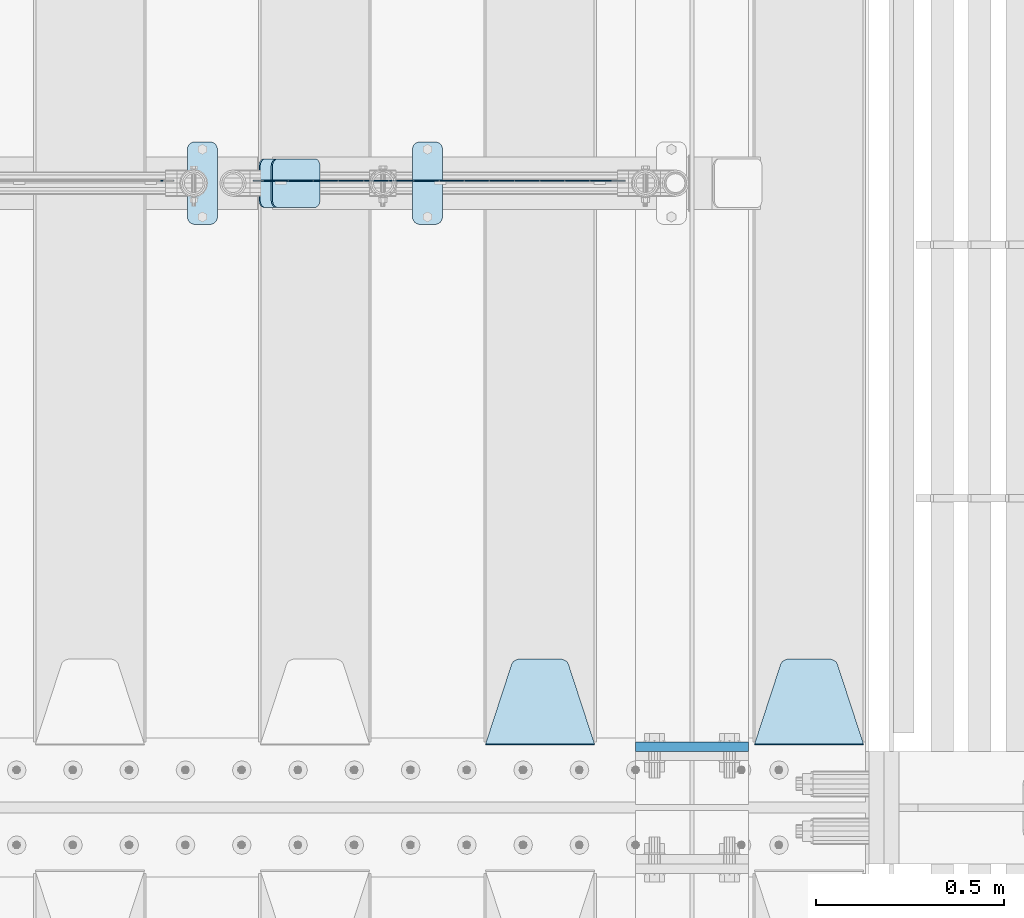
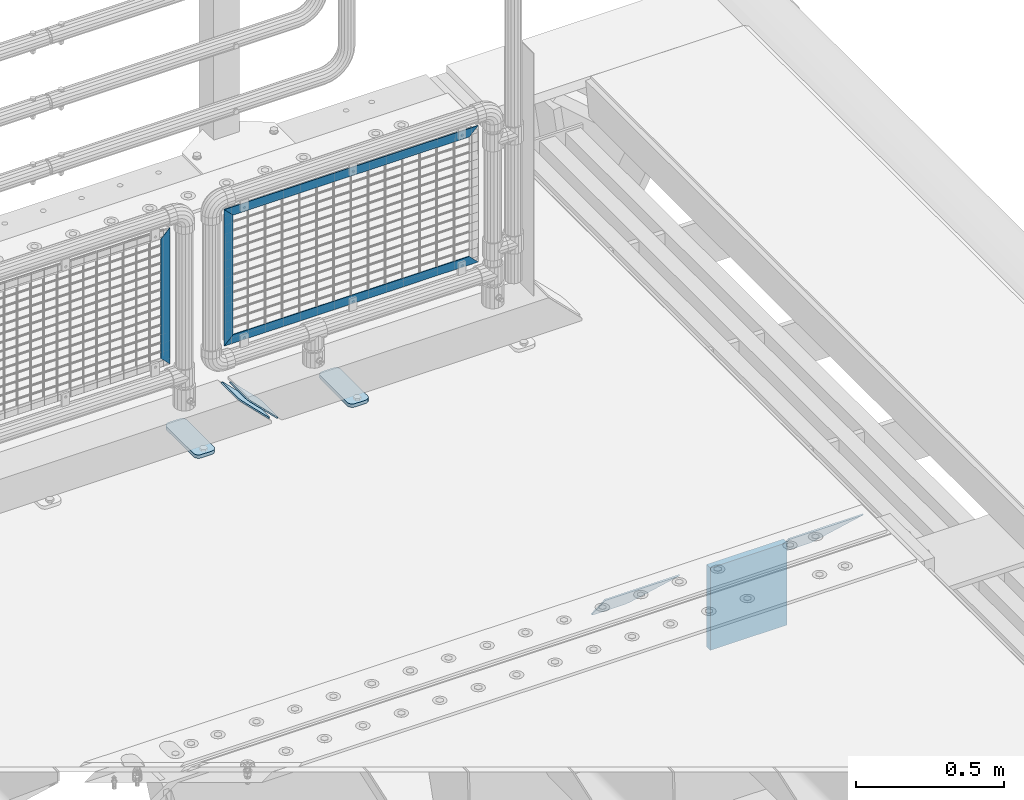
# One storey, part 177 of 193: 11 plates.
"""IFC2X3 building model written with IfcOpenShell, lengths in millimetres."""

from ifc_helpers import new_model, si_unit, frame, origin_with_axes, place, context, subcontext, project, spatial, faceted_brep, material, type_object, element, save


model = new_model("IFC2X3")

# Units and contexts
model_context = context("Model", 3, precision=1e-05, world=origin_with_axes())
body_context = subcontext(model_context, "Body", "Model", "MODEL_VIEW")
ifc_project = project(units=[si_unit("LENGTHUNIT", "METRE", prefix="MILLI"), si_unit("AREAUNIT", "SQUARE_METRE"), si_unit("VOLUMEUNIT", "CUBIC_METRE"), si_unit("MASSUNIT", "GRAM", prefix="KILO"), si_unit("TIMEUNIT", "SECOND"), si_unit("PLANEANGLEUNIT", "RADIAN"), si_unit("SOLIDANGLEUNIT", "STERADIAN"), si_unit("THERMODYNAMICTEMPERATUREUNIT", "DEGREE_CELSIUS"), si_unit("LUMINOUSINTENSITYUNIT", "LUMEN")], contexts=[model_context])

# Site, building, storey
site_placement = place(None, origin_with_axes())
site = spatial("IfcSite", under=ifc_project, at=site_placement, CompositionType="ELEMENT")
building_placement = place(site_placement, origin_with_axes())
building = spatial("IfcBuilding", under=site, at=building_placement, Name="Standard", CompositionType="ELEMENT")
storey_placement = place(building_placement, origin_with_axes())
storey = spatial("IfcBuildingStorey", under=building, at=storey_placement, Name="Undefined", CompositionType="ELEMENT", Elevation=0.0)

# Plates
ifc_material_1 = material(Name="STEEL/S355N")
plate_type_1 = type_object("IfcPlateType", PredefinedType="NOTDEFINED")
plate_1_placement = place(storey_placement, frame((-29045.0, 27162.5, -340.000000000044), z_axis=(0.0, 0.0, 1.0), x_axis=(1.0, 0.0, 0.0)))
element("IfcPlate", 1, at=plate_1_placement, inside=storey, type_object=plate_type_1, material=ifc_material_1, context=body_context, shape_type="Brep", body=[
    faceted_brep([(0.0, -12.5, 0.0), (9.27684595808387e-10, -12.5, 340.0), (9.27684595808387e-10, 12.5, 340.0), (0.0, 12.5, 0.0), (300.0, -12.5, 340.0), (300.0, 12.5, 340.0), (300.0, -12.5, 0.0), (300.0, 12.5, 0.0)], [[[0, 1, 2, 3]], [[1, 4, 5, 2]], [[4, 6, 7, 5]], [[6, 0, 3, 7]], [[5, 7, 3, 2]], [[6, 4, 1, 0]]]),
])
plate_type_2 = type_object("IfcPlateType", PredefinedType="NOTDEFINED")
plate_2_placement = place(storey_placement, frame((-28438.0, 27168.232233047, -1.76776695296758), z_axis=(0.0, 0.707106781186547, -0.707106781186548), x_axis=(-1.0, 0.0, 0.0)))
element("IfcPlate", 2, at=plate_2_placement, inside=storey, type_object=plate_type_2, material=ifc_material_1, context=body_context, shape_type="Brep", body=[
    faceted_brep([(0.0, -2.5, 0.0), (69.345504679477, -2.50000000000364, 300.171731424831), (69.345504679477, 2.49999999999636, 300.171731424831), (0.0, 2.5, 0.0), (70.9274061199576, -2.50000000000364, 304.897442415397), (70.9274061199576, 2.49999999999636, 304.897442415397), (73.3818627772307, -2.50000000000364, 309.234538108529), (73.3818627772307, 2.49999999999636, 309.234538108529), (76.6187032999551, -2.50000000000728, 313.023683126103), (76.6187032999551, 2.49999999999636, 313.023683126103), (80.5190132704993, -2.50000000000364, 316.125672595372), (80.5190132704993, 2.49999999999636, 316.125672595368), (84.9395038596849, -2.50000000000364, 318.426546230472), (84.9395038596849, 2.49999999999636, 318.426546230476), (89.7177759439219, -2.50000000000364, 319.841774983273), (89.7177759439219, 2.49999999999636, 319.841774983277), (94.678286292652, -2.50000000000364, 320.319366455074), (94.678286292652, 2.49999999999636, 320.319366455074), (195.321713707348, -2.50000000000364, 320.319366455074), (195.321713707348, 2.49999999999636, 320.319366455074), (200.282224056078, -2.50000000000364, 319.841774983273), (200.282224056078, 2.49999999999636, 319.841774983277), (205.060496140315, -2.50000000000364, 318.426546230472), (205.060496140315, 2.49999999999636, 318.426546230472), (209.480986729501, -2.50000000000364, 316.125672595372), (209.480986729501, 2.49999999999636, 316.125672595368), (213.381296700045, -2.50000000000728, 313.023683126103), (213.381296700045, 2.49999999999272, 313.023683126103), (216.618137222769, -2.50000000000364, 309.234538108525), (216.618137222769, 2.49999999999636, 309.234538108522), (219.072593880042, -2.50000000000364, 304.897442415397), (219.072593880042, 2.49999999999636, 304.897442415397), (220.654495320523, -2.50000000000364, 300.171731424831), (220.654495320523, 2.49999999999636, 300.171731424831), (290.0, -2.50000000000364, 0.0), (290.0, 2.49999999999636, 0.0)], [[[0, 1, 2, 3]], [[1, 4, 5, 2]], [[4, 6, 7, 5]], [[6, 8, 9, 7]], [[8, 10, 11, 9]], [[10, 12, 13, 11]], [[12, 14, 15, 13]], [[14, 16, 17, 15]], [[16, 18, 19, 17]], [[18, 20, 21, 19]], [[20, 22, 23, 21]], [[22, 24, 25, 23]], [[24, 26, 27, 25]], [[26, 28, 29, 27]], [[28, 30, 31, 29]], [[30, 32, 33, 31]], [[32, 34, 35, 33]], [[34, 0, 3, 35]], [[5, 7, 9, 11, 13, 15, 17, 19, 21, 23, 25, 27, 29, 31, 33, 35, 3, 2]], [[34, 32, 30, 28, 26, 24, 22, 20, 18, 16, 14, 12, 10, 8, 6, 4, 1, 0]]]),
])
plate_3_placement = place(storey_placement, frame((-29155.0, 27168.232233047, -1.76776695296758), z_axis=(0.0, 0.707106781186547, -0.707106781186548), x_axis=(-1.0, 0.0, 0.0)))
element("IfcPlate", 3, at=plate_3_placement, inside=storey, type_object=plate_type_2, material=ifc_material_1, context=body_context, shape_type="Brep", body=[
    faceted_brep([(0.0, -2.5, 0.0), (69.345504679477, -2.50000000000364, 300.171731424831), (69.345504679477, 2.49999999999636, 300.171731424831), (0.0, 2.5, 0.0), (70.9274061199576, -2.50000000000364, 304.897442415397), (70.9274061199576, 2.49999999999636, 304.897442415397), (73.3818627772307, -2.50000000000364, 309.234538108529), (73.3818627772307, 2.49999999999636, 309.234538108529), (76.6187032999551, -2.50000000000728, 313.023683126103), (76.6187032999551, 2.49999999999636, 313.023683126103), (80.5190132704993, -2.50000000000364, 316.125672595372), (80.5190132704993, 2.49999999999636, 316.125672595368), (84.9395038596849, -2.50000000000364, 318.426546230472), (84.9395038596849, 2.49999999999636, 318.426546230476), (89.7177759439219, -2.50000000000364, 319.841774983273), (89.7177759439219, 2.49999999999636, 319.841774983277), (94.678286292652, -2.50000000000364, 320.319366455074), (94.678286292652, 2.49999999999636, 320.319366455074), (195.321713707348, -2.50000000000364, 320.319366455074), (195.321713707348, 2.49999999999636, 320.319366455074), (200.282224056078, -2.50000000000364, 319.841774983273), (200.282224056078, 2.49999999999636, 319.841774983277), (205.060496140315, -2.50000000000364, 318.426546230472), (205.060496140315, 2.49999999999636, 318.426546230472), (209.480986729501, -2.50000000000364, 316.125672595372), (209.480986729501, 2.49999999999636, 316.125672595368), (213.381296700045, -2.50000000000728, 313.023683126103), (213.381296700045, 2.49999999999272, 313.023683126103), (216.618137222769, -2.50000000000364, 309.234538108525), (216.618137222769, 2.49999999999636, 309.234538108522), (219.072593880042, -2.50000000000364, 304.897442415397), (219.072593880042, 2.49999999999636, 304.897442415397), (220.654495320523, -2.50000000000364, 300.171731424831), (220.654495320523, 2.49999999999636, 300.171731424831), (290.0, -2.50000000000364, 0.0), (290.0, 2.49999999999636, 0.0)], [[[0, 1, 2, 3]], [[1, 4, 5, 2]], [[4, 6, 7, 5]], [[6, 8, 9, 7]], [[8, 10, 11, 9]], [[10, 12, 13, 11]], [[12, 14, 15, 13]], [[14, 16, 17, 15]], [[16, 18, 19, 17]], [[18, 20, 21, 19]], [[20, 22, 23, 21]], [[22, 24, 25, 23]], [[24, 26, 27, 25]], [[26, 28, 29, 27]], [[28, 30, 31, 29]], [[30, 32, 33, 31]], [[32, 34, 35, 33]], [[34, 0, 3, 35]], [[5, 7, 9, 11, 13, 15, 17, 19, 21, 23, 25, 27, 29, 31, 33, 35, 3, 2]], [[34, 32, 30, 28, 26, 24, 22, 20, 18, 16, 14, 12, 10, 8, 6, 4, 1, 0]]]),
])
ifc_material_2 = material(Name="Misc_Undefined")
plate_type_3 = type_object("IfcPlateType", PredefinedType="NOTDEFINED")
plate_4_placement = place(storey_placement, frame((-30029.8899741176, 28670.4999645044, 879.520017263591), z_axis=(-0.707106781186548, 0.0, -0.707106781186548), x_axis=(-0.707106781186548, 0.0, 0.707106781186548)))
element("IfcPlate", 4, at=plate_4_placement, inside=storey, type_object=plate_type_3, material=ifc_material_2, context=body_context, shape_type="Brep", body=[
    faceted_brep([(0.0, -1.49999999999636, 3.63797880709171e-12), (-348.603637695382, -1.49999999999636, 348.603668212894), (-348.603637695382, 1.50000000000364, 348.603668212891), (0.0, 1.50000000000364, 7.27595761418343e-12), (-348.603637695389, -1.49999999999636, 398.101165771488), (-348.603637695385, 1.50000000000364, 398.101165771488), (49.4974975585938, -1.5, 2.5465851649642e-11), (49.4974975585938, 1.50000000000364, 2.5465851649642e-11)], [[[0, 1, 2, 3]], [[1, 4, 5, 2]], [[4, 6, 7, 5]], [[6, 0, 3, 7]], [[5, 7, 3, 2]], [[6, 4, 1, 0]]]),
])
plate_5_placement = place(storey_placement, frame((-30029.8899996664, 28670.4999883292, 386.520006105211), z_axis=(0.707106781186548, 0.0, -0.707106781186548), x_axis=(-0.707106781186548, 0.0, -0.707106781186548)))
element("IfcPlate", 5, at=plate_5_placement, inside=storey, type_object=plate_type_3, material=ifc_material_2, context=body_context, shape_type="Brep", body=[
    faceted_brep([(0.0, -1.49999999999636, 3.63797880709171e-12), (-651.521057128932, -1.49999999999636, 651.521179199211), (-651.521057128935, 1.50000000000364, 651.521179199211), (0.0, 1.50000000000364, 7.27595761418343e-12), (-651.521057128939, -1.49999999999636, 701.018676757805), (-651.521057128935, 1.50000000000364, 701.018676757809), (49.4974975585938, -1.5, 2.5465851649642e-11), (49.4974975585938, 1.50000000000364, 2.5465851649642e-11)], [[[0, 1, 2, 3]], [[1, 4, 5, 2]], [[4, 6, 7, 5]], [[6, 0, 3, 7]], [[5, 7, 3, 2]], [[6, 4, 1, 0]]]),
])
plate_6_placement = place(storey_placement, frame((-29073.5000006033, 28670.4997837706, 914.520000514844), z_axis=(-0.707106781186548, 0.0, 0.707106781186548), x_axis=(-0.707106781186548, 0.0, -0.707106781186548)))
element("IfcPlate", 6, at=plate_6_placement, inside=storey, type_object=plate_type_3, material=ifc_material_2, context=body_context, shape_type="Brep", body=[
    faceted_brep([(0.0, -1.49999999999636, 3.63797880709171e-12), (701.01855468754, -1.50000000000728, 701.018615722656), (701.01855468754, 1.49999999999272, 701.018615722656), (0.0, 1.50000000000364, 7.27595761418343e-12), (701.018554687536, -1.50000000000728, 651.521118164059), (701.018554687536, 1.49999999999272, 651.521118164063), (49.4974975585938, -1.5, 2.5465851649642e-11), (49.4974975585938, 1.50000000000364, 2.5465851649642e-11)], [[[0, 1, 2, 3]], [[1, 4, 5, 2]], [[4, 6, 7, 5]], [[6, 0, 3, 7]], [[5, 7, 3, 2]], [[6, 4, 1, 0]]]),
])
plate_7_placement = place(storey_placement, frame((-30311.5003125164, 28670.5, 879.52), z_axis=(0.707103624179499, 0.0, -0.707109938179501), x_axis=(0.707109938179495, 0.0, 0.707103624179505)))
element("IfcPlate", 7, at=plate_7_placement, inside=storey, type_object=plate_type_3, material=ifc_material_2, context=body_context, shape_type="Brep", body=[
    faceted_brep([(0.0, -1.49999999999636, 3.63797880709171e-12), (-348.605163574215, -1.5, 348.602081298824), (-348.605163574215, 1.5, 348.602081298824), (0.0, 1.50000000000364, 7.27595761418343e-12), (-348.605163574215, -1.5, 398.099334716793), (-348.605163574215, 1.5, 398.099334716793), (49.4976959228552, -1.5, -1.01863406598568e-10), (49.4976959228552, 1.5, -1.01863406598568e-10)], [[[0, 1, 2, 3]], [[1, 4, 5, 2]], [[4, 6, 7, 5]], [[6, 0, 3, 7]], [[5, 7, 3, 2]], [[6, 4, 1, 0]]]),
])
ifc_material_3 = material(Name="STEEL/S355J2")
plate_type_4 = type_object("IfcPlateType", PredefinedType="NOTDEFINED")
plate_8_placement = place(storey_placement, frame((-30240.0, 28774.5, 21.0199999999977), z_axis=(1.0, 0.0, 0.0), x_axis=(0.0, -1.0, 0.0)))
element("IfcPlate", 8, at=plate_8_placement, inside=storey, type_object=plate_type_4, material=ifc_material_3, context=body_context, shape_type="Brep", body=[
    faceted_brep([(0.0, -7.0, 20.0), (0.0, -7.0, 60.0), (0.0, 7.0, 60.0), (0.0, 7.0, 20.0), (0.384294391937146, -7.0, 63.9018064403208), (0.384294391937146, 7.0, 63.9018064403208), (1.52240934977453, -7.0, 67.6536686473009), (1.52240934977453, 7.0, 67.6536686473009), (3.37060775395003, -7.0, 71.1114046603907), (3.37060775395003, 7.0, 71.1114046603907), (5.8578643762703, -7.0, 74.1421356237297), (5.8578643762703, 7.0, 74.1421356237297), (8.88859533960931, -7.0, 76.62939224605), (8.88859533960931, 7.0, 76.62939224605), (12.3463313526991, -7.0, 78.4775906502255), (12.3463313526991, 7.0, 78.4775906502255), (16.0981935596792, -7.0, 79.6157056080629), (16.0981935596792, 7.0, 79.6157056080629), (20.0, -7.0, 80.0), (20.0, 7.0, 80.0), (200.0, -7.0, 80.0), (200.0, 7.0, 80.0), (203.901806440321, -7.0, 79.6157056080629), (203.901806440321, 7.0, 79.6157056080629), (207.653668647301, -7.0, 78.4775906502255), (207.653668647301, 7.0, 78.4775906502255), (211.111404660391, -7.0, 76.62939224605), (211.111404660391, 7.0, 76.62939224605), (214.14213562373, -7.0, 74.1421356237297), (214.14213562373, 7.0, 74.1421356237297), (216.62939224605, -7.0, 71.1114046603907), (216.62939224605, 7.0, 71.1114046603907), (218.477590650225, -7.0, 67.6536686473009), (218.477590650225, 7.0, 67.6536686473009), (219.615705608063, -7.0, 63.9018064403208), (219.615705608063, 7.0, 63.9018064403208), (220.0, -7.0, 60.0), (220.0, 7.0, 60.0), (220.0, -7.0, 20.0), (220.0, 7.0, 20.0), (219.615705608063, -7.0, 16.0981935596792), (219.615705608063, 7.0, 16.0981935596792), (218.477590650225, -7.0, 12.3463313526991), (218.477590650225, 7.0, 12.3463313526991), (216.62939224605, -7.0, 8.88859533960931), (216.62939224605, 7.0, 8.88859533960931), (214.14213562373, -7.0, 5.8578643762703), (214.14213562373, 7.0, 5.8578643762703), (211.111404660391, -7.0, 3.37060775395003), (211.111404660391, 7.0, 3.37060775395003), (207.653668647301, -7.0, 1.52240934977453), (207.653668647301, 7.0, 1.52240934977453), (203.901806440321, -7.0, 0.384294391937146), (203.901806440321, 7.0, 0.384294391937146), (200.0, -7.0, 0.0), (200.0, 7.0, 0.0), (20.0, -7.0, 0.0), (20.0, 7.0, 0.0), (16.0981935596792, -7.0, 0.384294391937146), (16.0981935596792, 7.0, 0.384294391937146), (12.3463313526991, -7.0, 1.52240934977453), (12.3463313526991, 7.0, 1.52240934977453), (8.88859533960931, -7.0, 3.37060775395003), (8.88859533960931, 7.0, 3.37060775395003), (5.8578643762703, -7.0, 5.8578643762703), (5.8578643762703, 7.0, 5.8578643762703), (3.37060775395003, -7.0, 8.88859533960931), (3.37060775395003, 7.0, 8.88859533960931), (1.52240934977453, -7.0, 12.3463313526991), (1.52240934977453, 7.0, 12.3463313526991), (0.384294391937146, -7.0, 16.0981935596792), (0.384294391937146, 7.0, 16.0981935596792)], [[[0, 1, 2, 3]], [[1, 4, 5, 2]], [[4, 6, 7, 5]], [[6, 8, 9, 7]], [[8, 10, 11, 9]], [[10, 12, 13, 11]], [[12, 14, 15, 13]], [[14, 16, 17, 15]], [[16, 18, 19, 17]], [[18, 20, 21, 19]], [[20, 22, 23, 21]], [[22, 24, 25, 23]], [[24, 26, 27, 25]], [[26, 28, 29, 27]], [[28, 30, 31, 29]], [[30, 32, 33, 31]], [[32, 34, 35, 33]], [[34, 36, 37, 35]], [[36, 38, 39, 37]], [[38, 40, 41, 39]], [[40, 42, 43, 41]], [[42, 44, 45, 43]], [[44, 46, 47, 45]], [[46, 48, 49, 47]], [[48, 50, 51, 49]], [[50, 52, 53, 51]], [[52, 54, 55, 53]], [[54, 56, 57, 55]], [[56, 58, 59, 57]], [[58, 60, 61, 59]], [[60, 62, 63, 61]], [[62, 64, 65, 63]], [[64, 66, 67, 65]], [[66, 68, 69, 67]], [[68, 70, 71, 69]], [[70, 0, 3, 71]], [[5, 7, 9, 11, 13, 15, 17, 19, 21, 23, 25, 27, 29, 31, 33, 35, 37, 39, 41, 43, 45, 47, 49, 51, 53, 55, 57, 59, 61, 63, 65, 67, 69, 71, 3, 2]], [[70, 68, 66, 64, 62, 60, 58, 56, 54, 52, 50, 48, 46, 44, 42, 40, 38, 36, 34, 32, 30, 28, 26, 24, 22, 20, 18, 16, 14, 12, 10, 8, 6, 4, 1, 0]]]),
])
plate_9_placement = place(storey_placement, frame((-29640.0, 28774.5, 21.0199999999977), z_axis=(1.0, 0.0, 0.0), x_axis=(0.0, -1.0, 0.0)))
element("IfcPlate", 9, at=plate_9_placement, inside=storey, type_object=plate_type_4, material=ifc_material_3, context=body_context, shape_type="Brep", body=[
    faceted_brep([(0.0, -7.0, 20.0), (0.0, -7.0, 60.0), (0.0, 7.0, 60.0), (0.0, 7.0, 20.0), (0.384294391937146, -7.0, 63.9018064403208), (0.384294391937146, 7.0, 63.9018064403208), (1.52240934977453, -7.0, 67.6536686473009), (1.52240934977453, 7.0, 67.6536686473009), (3.37060775395003, -7.0, 71.1114046603907), (3.37060775395003, 7.0, 71.1114046603907), (5.8578643762703, -7.0, 74.1421356237297), (5.8578643762703, 7.0, 74.1421356237297), (8.88859533960931, -7.0, 76.62939224605), (8.88859533960931, 7.0, 76.62939224605), (12.3463313526991, -7.0, 78.4775906502255), (12.3463313526991, 7.0, 78.4775906502255), (16.0981935596792, -7.0, 79.6157056080629), (16.0981935596792, 7.0, 79.6157056080629), (20.0, -7.0, 80.0), (20.0, 7.0, 80.0), (200.0, -7.0, 80.0), (200.0, 7.0, 80.0), (203.901806440321, -7.0, 79.6157056080629), (203.901806440321, 7.0, 79.6157056080629), (207.653668647301, -7.0, 78.4775906502255), (207.653668647301, 7.0, 78.4775906502255), (211.111404660391, -7.0, 76.62939224605), (211.111404660391, 7.0, 76.62939224605), (214.14213562373, -7.0, 74.1421356237297), (214.14213562373, 7.0, 74.1421356237297), (216.62939224605, -7.0, 71.1114046603907), (216.62939224605, 7.0, 71.1114046603907), (218.477590650225, -7.0, 67.6536686473009), (218.477590650225, 7.0, 67.6536686473009), (219.615705608063, -7.0, 63.9018064403208), (219.615705608063, 7.0, 63.9018064403208), (220.0, -7.0, 60.0), (220.0, 7.0, 60.0), (220.0, -7.0, 20.0), (220.0, 7.0, 20.0), (219.615705608063, -7.0, 16.0981935596792), (219.615705608063, 7.0, 16.0981935596792), (218.477590650225, -7.0, 12.3463313526991), (218.477590650225, 7.0, 12.3463313526991), (216.62939224605, -7.0, 8.88859533960931), (216.62939224605, 7.0, 8.88859533960931), (214.14213562373, -7.0, 5.8578643762703), (214.14213562373, 7.0, 5.8578643762703), (211.111404660391, -7.0, 3.37060775395003), (211.111404660391, 7.0, 3.37060775395003), (207.653668647301, -7.0, 1.52240934977453), (207.653668647301, 7.0, 1.52240934977453), (203.901806440321, -7.0, 0.384294391937146), (203.901806440321, 7.0, 0.384294391937146), (200.0, -7.0, 0.0), (200.0, 7.0, 0.0), (20.0, -7.0, 0.0), (20.0, 7.0, 0.0), (16.0981935596792, -7.0, 0.384294391937146), (16.0981935596792, 7.0, 0.384294391937146), (12.3463313526991, -7.0, 1.52240934977453), (12.3463313526991, 7.0, 1.52240934977453), (8.88859533960931, -7.0, 3.37060775395003), (8.88859533960931, 7.0, 3.37060775395003), (5.8578643762703, -7.0, 5.8578643762703), (5.8578643762703, 7.0, 5.8578643762703), (3.37060775395003, -7.0, 8.88859533960931), (3.37060775395003, 7.0, 8.88859533960931), (1.52240934977453, -7.0, 12.3463313526991), (1.52240934977453, 7.0, 12.3463313526991), (0.384294391937146, -7.0, 16.0981935596792), (0.384294391937146, 7.0, 16.0981935596792)], [[[0, 1, 2, 3]], [[1, 4, 5, 2]], [[4, 6, 7, 5]], [[6, 8, 9, 7]], [[8, 10, 11, 9]], [[10, 12, 13, 11]], [[12, 14, 15, 13]], [[14, 16, 17, 15]], [[16, 18, 19, 17]], [[18, 20, 21, 19]], [[20, 22, 23, 21]], [[22, 24, 25, 23]], [[24, 26, 27, 25]], [[26, 28, 29, 27]], [[28, 30, 31, 29]], [[30, 32, 33, 31]], [[32, 34, 35, 33]], [[34, 36, 37, 35]], [[36, 38, 39, 37]], [[38, 40, 41, 39]], [[40, 42, 43, 41]], [[42, 44, 45, 43]], [[44, 46, 47, 45]], [[46, 48, 49, 47]], [[48, 50, 51, 49]], [[50, 52, 53, 51]], [[52, 54, 55, 53]], [[54, 56, 57, 55]], [[56, 58, 59, 57]], [[58, 60, 61, 59]], [[60, 62, 63, 61]], [[62, 64, 65, 63]], [[64, 66, 67, 65]], [[66, 68, 69, 67]], [[68, 70, 71, 69]], [[70, 0, 3, 71]], [[5, 7, 9, 11, 13, 15, 17, 19, 21, 23, 25, 27, 29, 31, 33, 35, 37, 39, 41, 43, 45, 47, 49, 51, 53, 55, 57, 59, 61, 63, 65, 67, 69, 71, 3, 2]], [[70, 68, 66, 64, 62, 60, 58, 56, 54, 52, 50, 48, 46, 44, 42, 40, 38, 36, 34, 32, 30, 28, 26, 24, 22, 20, 18, 16, 14, 12, 10, 8, 6, 4, 1, 0]]]),
])
plate_type_5 = type_object("IfcPlateType", PredefinedType="NOTDEFINED")
plate_10_placement = place(storey_placement, frame((-30047.807581521, 28729.5, 166.254400376563), z_axis=(0.707410512925777, 0.0, -0.706802918925841), x_axis=(0.0, -1.0, 0.0)))
element("IfcPlate", 10, at=plate_10_placement, inside=storey, type_object=plate_type_5, material=ifc_material_3, context=body_context, shape_type="Brep", body=[
    faceted_brep([(0.0, -2.49999999999636, 20.0), (0.0, -2.5, 158.926651000977), (0.0, 2.50000000000364, 158.926651000977), (0.0, 2.5, 20.0), (0.384294391937146, -2.49999999999636, 162.828457441297), (0.384294391937146, 2.50000000000364, 162.828457441297), (1.52240934977453, -2.49999999999636, 166.580319648278), (1.52240934977453, 2.50000000000364, 166.580319648278), (3.37060775395003, -2.49999999999636, 170.038055661367), (3.37060775395003, 2.5, 170.038055661367), (5.8578643762703, -2.49999999999636, 173.068786624706), (5.8578643762703, 2.5, 173.06878662471), (8.88859533960931, -2.5, 175.55604324703), (8.88859533960931, 2.50000000000364, 175.55604324703), (12.3463313526991, -2.49999999999636, 177.404241651202), (12.3463313526991, 2.5, 177.404241651202), (16.0981935596792, -2.49999999999636, 178.542356609043), (16.0981935596792, 2.50000000000364, 178.542356609039), (20.0, -2.49999999999636, 178.926651000973), (20.0, 2.50000000000364, 178.926651000977), (110.0, -2.49999999999636, 178.926651000973), (110.0, 2.50000000000364, 178.926651000977), (113.901806440321, -2.49999999999636, 178.542356609043), (113.901806440321, 2.50000000000364, 178.542356609039), (117.653668647301, -2.49999999999636, 177.404241651202), (117.653668647301, 2.5, 177.404241651202), (121.111404660391, -2.5, 175.55604324703), (121.111404660391, 2.50000000000364, 175.55604324703), (124.14213562373, -2.49999999999636, 173.068786624706), (124.14213562373, 2.5, 173.06878662471), (126.62939224605, -2.49999999999636, 170.038055661367), (126.62939224605, 2.5, 170.038055661367), (128.477590650225, -2.49999999999636, 166.580319648278), (128.477590650225, 2.50000000000364, 166.580319648278), (129.615705608063, -2.49999999999636, 162.828457441297), (129.615705608063, 2.50000000000364, 162.828457441297), (130.0, -2.5, 158.926651000977), (130.0, 2.50000000000364, 158.926651000977), (130.0, -2.49999999999636, 20.0), (130.0, 2.5, 20.0), (129.615705608063, -2.49999999999636, 16.0981935596792), (129.615705608063, 2.5, 16.0981935596792), (128.477590650225, -2.49999999999636, 12.3463313526991), (128.477590650225, 2.50000000000364, 12.3463313526991), (126.62939224605, -2.5, 8.88859533960931), (126.62939224605, 2.5, 8.88859533960931), (124.14213562373, -2.5, 5.8578643762703), (124.14213562373, 2.5, 5.8578643762703), (121.111404660391, -2.49999999999636, 3.37060775395003), (121.111404660391, 2.5, 3.37060775395003), (117.653668647301, -2.49999999999636, 1.52240934977453), (117.653668647301, 2.50000000000364, 1.52240934977453), (113.901806440321, -2.49999999999636, 0.384294391933508), (113.901806440321, 2.50000000000364, 0.384294391937146), (110.0, -2.49999999999636, 0.0), (110.0, 2.50000000000364, 0.0), (20.0, -2.49999999999636, 0.0), (20.0, 2.50000000000364, 0.0), (16.0981935596792, -2.49999999999636, 0.384294391933508), (16.0981935596792, 2.50000000000364, 0.384294391937146), (12.3463313526991, -2.49999999999636, 1.52240934977453), (12.3463313526991, 2.50000000000364, 1.52240934977453), (8.88859533960931, -2.49999999999636, 3.37060775395003), (8.88859533960931, 2.5, 3.37060775395003), (5.8578643762703, -2.5, 5.8578643762703), (5.8578643762703, 2.5, 5.8578643762703), (3.37060775395003, -2.5, 8.88859533960931), (3.37060775395003, 2.5, 8.88859533960931), (1.52240934977453, -2.49999999999636, 12.3463313526991), (1.52240934977453, 2.50000000000364, 12.3463313526991), (0.384294391937146, -2.49999999999636, 16.0981935596792), (0.384294391937146, 2.5, 16.0981935596792)], [[[0, 1, 2, 3]], [[1, 4, 5, 2]], [[4, 6, 7, 5]], [[6, 8, 9, 7]], [[8, 10, 11, 9]], [[10, 12, 13, 11]], [[12, 14, 15, 13]], [[14, 16, 17, 15]], [[16, 18, 19, 17]], [[18, 20, 21, 19]], [[20, 22, 23, 21]], [[22, 24, 25, 23]], [[24, 26, 27, 25]], [[26, 28, 29, 27]], [[28, 30, 31, 29]], [[30, 32, 33, 31]], [[32, 34, 35, 33]], [[34, 36, 37, 35]], [[36, 38, 39, 37]], [[38, 40, 41, 39]], [[40, 42, 43, 41]], [[42, 44, 45, 43]], [[44, 46, 47, 45]], [[46, 48, 49, 47]], [[48, 50, 51, 49]], [[50, 52, 53, 51]], [[52, 54, 55, 53]], [[54, 56, 57, 55]], [[56, 58, 59, 57]], [[58, 60, 61, 59]], [[60, 62, 63, 61]], [[62, 64, 65, 63]], [[64, 66, 67, 65]], [[66, 68, 69, 67]], [[68, 70, 71, 69]], [[70, 0, 3, 71]], [[5, 7, 9, 11, 13, 15, 17, 19, 21, 23, 25, 27, 29, 31, 33, 35, 37, 39, 41, 43, 45, 47, 49, 51, 53, 55, 57, 59, 61, 63, 65, 67, 69, 71, 3, 2]], [[70, 68, 66, 64, 62, 60, 58, 56, 54, 52, 50, 48, 46, 44, 42, 40, 38, 36, 34, 32, 30, 28, 26, 24, 22, 20, 18, 16, 14, 12, 10, 8, 6, 4, 1, 0]]]),
])
plate_11_placement = place(storey_placement, frame((-30014.8785177832, 28729.5, 156.251454056258), z_axis=(0.707418377001898, 0.0, -0.706795048001895), x_axis=(0.0, -1.0, 0.0)))
element("IfcPlate", 11, at=plate_11_placement, inside=storey, type_object=plate_type_5, material=ifc_material_3, context=body_context, shape_type="Brep", body=[
    faceted_brep([(0.0, -2.49999999999636, 20.0), (0.0, -2.5, 158.926651000977), (0.0, 2.50000000000364, 158.926651000977), (0.0, 2.5, 20.0), (0.384294391937146, -2.49999999999636, 162.828457441297), (0.384294391937146, 2.50000000000364, 162.828457441297), (1.52240934977453, -2.49999999999636, 166.580319648278), (1.52240934977453, 2.50000000000364, 166.580319648278), (3.37060775395003, -2.49999999999636, 170.038055661367), (3.37060775395003, 2.5, 170.038055661367), (5.8578643762703, -2.49999999999636, 173.068786624706), (5.8578643762703, 2.5, 173.06878662471), (8.88859533960931, -2.5, 175.55604324703), (8.88859533960931, 2.50000000000364, 175.55604324703), (12.3463313526991, -2.49999999999636, 177.404241651202), (12.3463313526991, 2.5, 177.404241651202), (16.0981935596792, -2.49999999999636, 178.542356609043), (16.0981935596792, 2.50000000000364, 178.542356609039), (20.0, -2.49999999999636, 178.926651000973), (20.0, 2.50000000000364, 178.926651000977), (110.0, -2.49999999999636, 178.926651000973), (110.0, 2.50000000000364, 178.926651000977), (113.901806440321, -2.49999999999636, 178.542356609043), (113.901806440321, 2.50000000000364, 178.542356609039), (117.653668647301, -2.49999999999636, 177.404241651202), (117.653668647301, 2.5, 177.404241651202), (121.111404660391, -2.5, 175.55604324703), (121.111404660391, 2.50000000000364, 175.55604324703), (124.14213562373, -2.49999999999636, 173.068786624706), (124.14213562373, 2.5, 173.06878662471), (126.62939224605, -2.49999999999636, 170.038055661367), (126.62939224605, 2.5, 170.038055661367), (128.477590650225, -2.49999999999636, 166.580319648278), (128.477590650225, 2.50000000000364, 166.580319648278), (129.615705608063, -2.49999999999636, 162.828457441297), (129.615705608063, 2.50000000000364, 162.828457441297), (130.0, -2.5, 158.926651000977), (130.0, 2.50000000000364, 158.926651000977), (130.0, -2.49999999999636, 20.0), (130.0, 2.5, 20.0), (129.615705608063, -2.49999999999636, 16.0981935596792), (129.615705608063, 2.5, 16.0981935596792), (128.477590650225, -2.49999999999636, 12.3463313526991), (128.477590650225, 2.50000000000364, 12.3463313526991), (126.62939224605, -2.5, 8.88859533960931), (126.62939224605, 2.5, 8.88859533960931), (124.14213562373, -2.5, 5.8578643762703), (124.14213562373, 2.5, 5.8578643762703), (121.111404660391, -2.49999999999636, 3.37060775395003), (121.111404660391, 2.5, 3.37060775395003), (117.653668647301, -2.49999999999636, 1.52240934977453), (117.653668647301, 2.50000000000364, 1.52240934977453), (113.901806440321, -2.49999999999636, 0.384294391933508), (113.901806440321, 2.50000000000364, 0.384294391937146), (110.0, -2.49999999999636, 0.0), (110.0, 2.50000000000364, 0.0), (20.0, -2.49999999999636, 0.0), (20.0, 2.50000000000364, 0.0), (16.0981935596792, -2.49999999999636, 0.384294391933508), (16.0981935596792, 2.50000000000364, 0.384294391937146), (12.3463313526991, -2.49999999999636, 1.52240934977453), (12.3463313526991, 2.50000000000364, 1.52240934977453), (8.88859533960931, -2.49999999999636, 3.37060775395003), (8.88859533960931, 2.5, 3.37060775395003), (5.8578643762703, -2.5, 5.8578643762703), (5.8578643762703, 2.5, 5.8578643762703), (3.37060775395003, -2.5, 8.88859533960931), (3.37060775395003, 2.5, 8.88859533960931), (1.52240934977453, -2.49999999999636, 12.3463313526991), (1.52240934977453, 2.50000000000364, 12.3463313526991), (0.384294391937146, -2.49999999999636, 16.0981935596792), (0.384294391937146, 2.5, 16.0981935596792)], [[[0, 1, 2, 3]], [[1, 4, 5, 2]], [[4, 6, 7, 5]], [[6, 8, 9, 7]], [[8, 10, 11, 9]], [[10, 12, 13, 11]], [[12, 14, 15, 13]], [[14, 16, 17, 15]], [[16, 18, 19, 17]], [[18, 20, 21, 19]], [[20, 22, 23, 21]], [[22, 24, 25, 23]], [[24, 26, 27, 25]], [[26, 28, 29, 27]], [[28, 30, 31, 29]], [[30, 32, 33, 31]], [[32, 34, 35, 33]], [[34, 36, 37, 35]], [[36, 38, 39, 37]], [[38, 40, 41, 39]], [[40, 42, 43, 41]], [[42, 44, 45, 43]], [[44, 46, 47, 45]], [[46, 48, 49, 47]], [[48, 50, 51, 49]], [[50, 52, 53, 51]], [[52, 54, 55, 53]], [[54, 56, 57, 55]], [[56, 58, 59, 57]], [[58, 60, 61, 59]], [[60, 62, 63, 61]], [[62, 64, 65, 63]], [[64, 66, 67, 65]], [[66, 68, 69, 67]], [[68, 70, 71, 69]], [[70, 0, 3, 71]], [[5, 7, 9, 11, 13, 15, 17, 19, 21, 23, 25, 27, 29, 31, 33, 35, 37, 39, 41, 43, 45, 47, 49, 51, 53, 55, 57, 59, 61, 63, 65, 67, 69, 71, 3, 2]], [[70, 68, 66, 64, 62, 60, 58, 56, 54, 52, 50, 48, 46, 44, 42, 40, 38, 36, 34, 32, 30, 28, 26, 24, 22, 20, 18, 16, 14, 12, 10, 8, 6, 4, 1, 0]]]),
])

save(model, "model.ifc")
